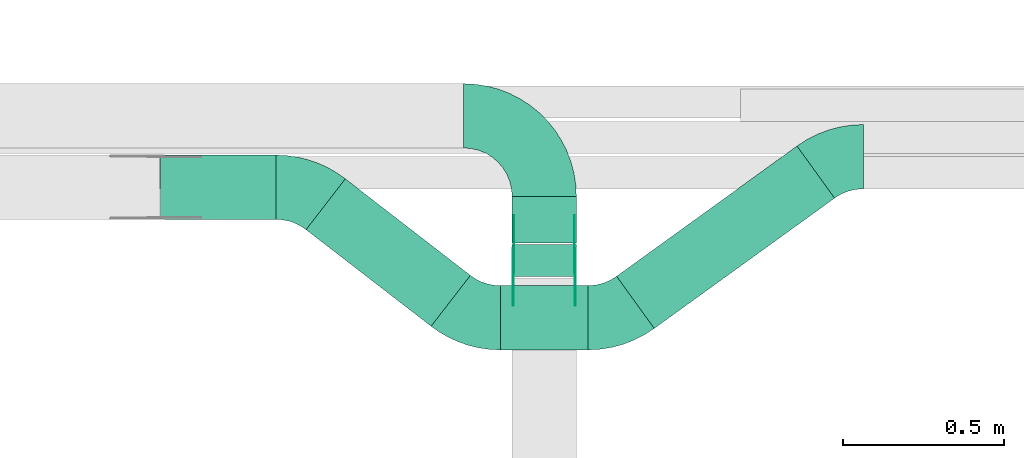
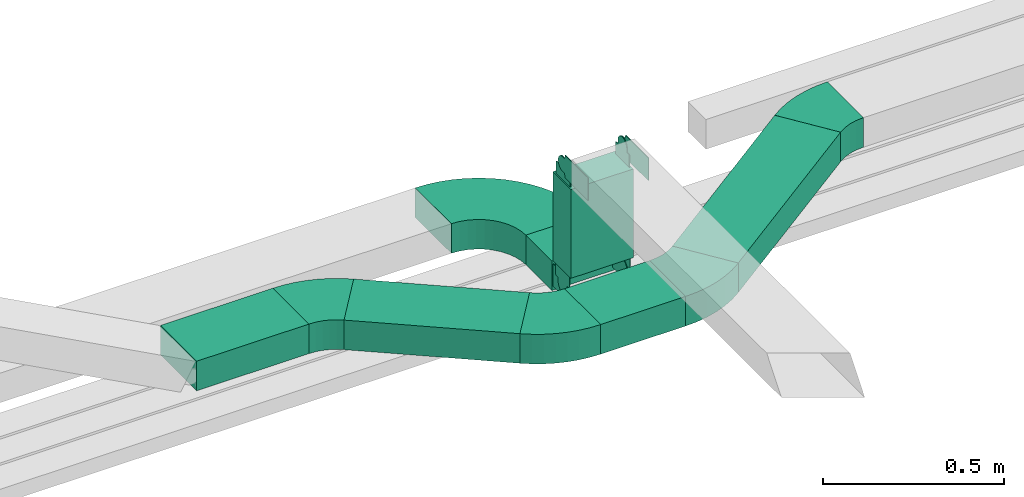
# One storey, part 5 of 23: 13 flow fittings, 6 flow segments.
"""IFC2X3 building model written with IfcOpenShell, lengths in millimetres."""

from ifc_helpers import new_model, entity, si_unit, converted_unit, derived_unit, direction, frame, frame_2d, origin, origin_2d_with_axis, place, context, subcontext, project, spatial, polyline, circle_curve, parameter, trimmed, segment, composite_curve, rectangle, outline, extrude, source, transform, mapped, material, type_object, type_shapes, element, save


model = new_model("IFC2X3")

# Units and contexts
model_context = context("Model", 3, precision=0.01, world=origin(), true_north=direction((6.12303176911189e-17, 1.0)))
body_context = subcontext(model_context, "Body", "Model", "MODEL_VIEW")
ifc_project = project(units=[si_unit("LENGTHUNIT", "METRE", prefix="MILLI"), si_unit("AREAUNIT", "SQUARE_METRE"), si_unit("VOLUMEUNIT", "CUBIC_METRE"), converted_unit("PLANEANGLEUNIT", "DEGREE", entity("IfcRatioMeasure", 0.0174532925199433), si_unit("PLANEANGLEUNIT", "RADIAN"), dimensions=[0, 0, 0, 0, 0, 0, 0]), si_unit("MASSUNIT", "GRAM", prefix="KILO"), derived_unit("MASSDENSITYUNIT", [(si_unit("MASSUNIT", "GRAM", prefix="KILO"), 1), (si_unit("LENGTHUNIT", "METRE"), -3)]), derived_unit("MOMENTOFINERTIAUNIT", [(si_unit("LENGTHUNIT", "METRE"), 4)]), si_unit("TIMEUNIT", "SECOND"), si_unit("FREQUENCYUNIT", "HERTZ"), si_unit("THERMODYNAMICTEMPERATUREUNIT", "DEGREE_CELSIUS"), derived_unit("THERMALTRANSMITTANCEUNIT", [(si_unit("MASSUNIT", "GRAM", prefix="KILO"), 1), (si_unit("THERMODYNAMICTEMPERATUREUNIT", "KELVIN"), -1), (si_unit("TIMEUNIT", "SECOND"), -3)]), derived_unit("VOLUMETRICFLOWRATEUNIT", [(si_unit("LENGTHUNIT", "METRE"), 3), (si_unit("TIMEUNIT", "SECOND"), -1)]), derived_unit("MASSFLOWRATEUNIT", [(si_unit("MASSUNIT", "GRAM", prefix="KILO"), 1), (si_unit("TIMEUNIT", "SECOND"), -1)]), derived_unit("ROTATIONALFREQUENCYUNIT", [(si_unit("TIMEUNIT", "SECOND"), -1)]), si_unit("ELECTRICCURRENTUNIT", "AMPERE"), si_unit("ELECTRICVOLTAGEUNIT", "VOLT"), si_unit("POWERUNIT", "WATT"), si_unit("FORCEUNIT", "NEWTON", prefix="KILO"), si_unit("ILLUMINANCEUNIT", "LUX"), si_unit("LUMINOUSFLUXUNIT", "LUMEN"), si_unit("LUMINOUSINTENSITYUNIT", "CANDELA"), derived_unit("USERDEFINED", [(si_unit("MASSUNIT", "GRAM", prefix="KILO"), -1), (si_unit("LENGTHUNIT", "METRE"), -2), (si_unit("TIMEUNIT", "SECOND"), 3), (si_unit("LUMINOUSFLUXUNIT", "LUMEN"), 1)]), derived_unit("LINEARVELOCITYUNIT", [(si_unit("LENGTHUNIT", "METRE"), 1), (si_unit("TIMEUNIT", "SECOND"), -1)]), si_unit("PRESSUREUNIT", "PASCAL"), derived_unit("USERDEFINED", [(si_unit("LENGTHUNIT", "METRE"), -2), (si_unit("MASSUNIT", "GRAM", prefix="KILO"), 1), (si_unit("TIMEUNIT", "SECOND"), -2)]), derived_unit("LINEARFORCEUNIT", [(si_unit("MASSUNIT", "GRAM", prefix="KILO"), 1), (si_unit("LENGTHUNIT", "METRE"), 1), (si_unit("TIMEUNIT", "SECOND"), -2), (si_unit("LENGTHUNIT", "METRE"), -1)]), derived_unit("PLANARFORCEUNIT", [(si_unit("MASSUNIT", "GRAM", prefix="KILO"), 1), (si_unit("LENGTHUNIT", "METRE"), 1), (si_unit("TIMEUNIT", "SECOND"), -2), (si_unit("LENGTHUNIT", "METRE"), -2)])], contexts=[model_context])

# Site, building, storey
site_placement = place(None, origin())
site = spatial("IfcSite", under=ifc_project, at=site_placement, CompositionType="ELEMENT")
building_placement = place(site_placement, origin())
building = spatial("IfcBuilding", under=site, at=building_placement, CompositionType="ELEMENT")
storey_placement = place(building_placement, frame((0.0, 0.0, 24000.0)))
storey = spatial("IfcBuildingStorey", under=building, at=storey_placement, CompositionType="ELEMENT", Elevation=24000.0)

# Flow segments
cable_carrier_segment_type = type_object("IfcCableCarrierSegmentType", PredefinedType="CABLETRAYSEGMENT")
flow_segment_1_placement = place(storey_placement, frame((22684.98, 9729.94, 2890.0)))
element("IfcFlowSegment", 1, at=flow_segment_1_placement, inside=storey, type_object=cable_carrier_segment_type, context=body_context, shape_type="SweptSolid", body=[
    extrude(rectangle(XDim=143.999999999998, YDim=199.999999999998, at=origin_2d_with_axis()), frame((100.0, 72.0, 0.0), z_axis=(0.0, 0.0, 1.0), x_axis=(0.0, -1.0, 0.0)), (0.0, 0.0, 1.0), 100.000000000003),
])
flow_segment_2_placement = place(storey_placement, frame((22684.98, 9624.94, 2995.0)))
element("IfcFlowSegment", 2, at=flow_segment_2_placement, inside=storey, type_object=cable_carrier_segment_type, context=body_context, shape_type="SweptSolid", body=[
    extrude(rectangle(XDim=199.999999999998, YDim=100.000000000001, at=origin_2d_with_axis()), frame((100.0, 50.0, 0.0)), (0.0, 0.0, 1.0), 299.999986293866),
])
flow_segment_3_placement = place(storey_placement, frame((21591.43, 9802.66, 2890.0)))
element("IfcFlowSegment", 3, at=flow_segment_3_placement, inside=storey, type_object=cable_carrier_segment_type, context=body_context, shape_type="SweptSolid", body=[
    extrude(rectangle(XDim=359.111266245777, YDim=199.999999999998, at=origin_2d_with_axis()), frame((179.56, 100.0, 0.0), z_axis=(0.0, 0.0, 1.0), x_axis=(-1.0, 0.0, 0.0)), (0.0, 0.0, 1.0), 100.000000000003),
])
flow_segment_4_placement = place(storey_placement, frame((22648.76, 9396.69, 2890.0)))
element("IfcFlowSegment", 4, at=flow_segment_4_placement, inside=storey, type_object=cable_carrier_segment_type, context=body_context, shape_type="SweptSolid", body=[
    extrude(rectangle(XDim=271.84445040066, YDim=200.0, at=origin_2d_with_axis()), frame((135.92, 100.0, 0.0)), (0.0, 0.0, 1.0), 100.000000000003),
])
flow_segment_5_placement = place(storey_placement, frame((22044.03, 9470.31, 2890.0)))
element("IfcFlowSegment", 5, at=flow_segment_5_placement, inside=storey, type_object=cable_carrier_segment_type, context=body_context, shape_type="SweptSolid", body=[
    extrude(rectangle(XDim=491.512542620555, YDim=200.000000000002, at=origin_2d_with_axis()), frame((255.62, 229.37, 0.0), z_axis=(0.0, 0.0, 1.0), x_axis=(-0.791406463891307, 0.611290282035514, 0.0)), (0.0, 0.0, 1.0), 100.000000000003),
])
flow_segment_6_placement = place(storey_placement, frame((23010.24, 9463.55, 2890.0)))
element("IfcFlowSegment", 6, at=flow_segment_6_placement, inside=storey, type_object=cable_carrier_segment_type, context=body_context, shape_type="SweptSolid", body=[
    extrude(rectangle(XDim=692.157993245641, YDim=200.0, at=origin_2d_with_axis()), frame((339.1, 283.71, 0.0), z_axis=(0.0, 0.0, 1.0), x_axis=(0.810643960277806, 0.585539383530361, 0.0)), (0.0, 0.0, 1.0), 100.000000000003),
])

# Flow fittings
ifc_material_1 = material()
cable_carrier_fitting_type_1 = type_object("IfcCableCarrierFittingType", Name="470_DKC_S5_Variable Angle Elbow 0-45:-", PredefinedType="NOTDEFINED", material=ifc_material_1)
shared_shape_1 = source(origin(), body_context, "Body", "SweptSolid", [
    extrude(outline(composite_curve([segment(polyline([(-125.75, -225.25), (-124.75, -225.25)]), True, "CONTINUOUS"), segment(trimmed(circle_curve(frame_2d((-124.75, 124.75), x_axis=(0.0, -1.0)), 350.0), [parameter(0.0)], [parameter(90.0000000000001)], True, "PARAMETER"), True, "CONTINUOUS"), segment(polyline([(225.25, 124.75), (225.25, 125.75)]), True, "CONTINUOUS"), segment(polyline([(225.25, 125.75), (25.25, 125.75)]), True, "CONTINUOUS"), segment(polyline([(25.25, 125.75), (25.25, 124.75)]), True, "CONTINUOUS"), segment(trimmed(circle_curve(frame_2d((-124.75, 124.75), x_axis=(0.0, -1.0)), 150.0), [parameter(0.0)], [parameter(90.0000000000001)], True, "PARAMETER"), False, "CONTINUOUS"), segment(polyline([(-124.75, -25.25), (-125.75, -25.25)]), True, "CONTINUOUS"), segment(polyline([(-125.75, -25.25), (-125.75, -225.25)]), True, "CONTINUOUS")], self_intersect=False)), frame((-125.25, 125.25, -50.0)), (0.0, 0.0, 1.0), 100.0),
])
type_shapes(cable_carrier_fitting_type_1, [shared_shape_1])
flow_fitting_1_placement = place(storey_placement, frame((22784.98, 10124.94, 2940.0), z_axis=(0.0, 0.0, 1.0), x_axis=(0.0, 1.0, 0.0)))
element("IfcFlowFitting", 7, at=flow_fitting_1_placement, inside=storey, type_object=cable_carrier_fitting_type_1, material=ifc_material_1, Name="470_DKC_S5_Variable Angle Elbow 0-45:-", ObjectType="470_DKC_S5_Variable Angle Elbow 0-45:-", context=body_context, shape_type="MappedRepresentation", body=[
    mapped(shared_shape_1, transform((0.0, 0.0, 0.0), scale=1.0)),
])
ifc_material_2 = material(Name="G")
cable_carrier_fitting_type_2 = type_object("IfcCableCarrierFittingType", PredefinedType="NOTDEFINED", material=ifc_material_2)
shared_shape_2 = source(origin(), body_context, "Body", "SweptSolid", [
    extrude(outline(composite_curve([segment(trimmed(circle_curve(frame_2d((-41.47, 0.0), x_axis=(1.0, 0.0)), 25.0), [parameter(90.0000000000007)], [parameter(270.0)], True, "PARAMETER"), True, "CONTINUOUS"), segment(polyline([(-41.47, -25.0), (-29.97, -25.0)]), True, "CONTINUOUS"), segment(polyline([(-29.97, -25.0), (-28.1, -38.5)]), True, "CONTINUOUS"), segment(polyline([(-28.1, -38.5), (99.53, -38.5)]), True, "CONTINUOUS"), segment(polyline([(99.53, -38.5), (99.53, 38.5)]), True, "CONTINUOUS"), segment(polyline([(99.53, 38.5), (-28.1, 38.5)]), True, "CONTINUOUS"), segment(polyline([(-28.1, 38.5), (-29.97, 25.0)]), True, "CONTINUOUS"), segment(polyline([(-29.97, 25.0), (-41.47, 25.0)]), True, "CONTINUOUS")], self_intersect=False)), frame((41.47, 0.0, 0.0), z_axis=(0.0, 0.0, -1.0), x_axis=(1.0, 0.0, 0.0)), (0.0, 0.0, -1.0), 2.0),
])
type_shapes(cable_carrier_fitting_type_2, [shared_shape_2])
flow_fitting_2_placement = place(storey_placement, frame((22880.44, 9674.94, 3350.0), z_axis=(1.0, 0.0, 0.0), x_axis=(0.0, -1.0, -2.53817257434008e-07)))
element("IfcFlowFitting", 8, at=flow_fitting_2_placement, inside=storey, type_object=cable_carrier_fitting_type_2, material=ifc_material_2, context=body_context, shape_type="MappedRepresentation", body=[
    mapped(shared_shape_2, transform((0.0, 0.0, 0.0), scale=1.0)),
])
cable_carrier_fitting_type_3 = type_object("IfcCableCarrierFittingType", PredefinedType="NOTDEFINED", material=ifc_material_2)
type_shapes(cable_carrier_fitting_type_3, [shared_shape_2])
flow_fitting_3_placement = place(storey_placement, frame((22691.52, 9674.94, 3350.0), z_axis=(-1.0, 0.0, 0.0), x_axis=(0.0, 0.0, -1.0)))
element("IfcFlowFitting", 9, at=flow_fitting_3_placement, inside=storey, type_object=cable_carrier_fitting_type_3, material=ifc_material_2, context=body_context, shape_type="MappedRepresentation", body=[
    mapped(shared_shape_2, transform((0.0, 0.0, 0.0), scale=1.0)),
])
flow_fitting_4_placement = place(storey_placement, frame((22689.52, 9674.94, 2940.0), z_axis=(-1.0, 0.0, 0.0), x_axis=(0.0, 0.0, 1.0)))
element("IfcFlowFitting", 10, at=flow_fitting_4_placement, inside=storey, type_object=cable_carrier_fitting_type_2, material=ifc_material_2, context=body_context, shape_type="MappedRepresentation", body=[
    mapped(shared_shape_2, transform((0.0, 0.0, 0.0), scale=1.0)),
])
flow_fitting_5_placement = place(storey_placement, frame((22878.44, 9674.94, 2940.0), z_axis=(1.0, 0.0, 0.0), x_axis=(0.0, 1.0, 0.0)))
element("IfcFlowFitting", 11, at=flow_fitting_5_placement, inside=storey, type_object=cable_carrier_fitting_type_3, material=ifc_material_2, context=body_context, shape_type="MappedRepresentation", body=[
    mapped(shared_shape_2, transform((0.0, 0.0, 0.0), scale=1.0)),
])
cable_carrier_fitting_type_4 = type_object("IfcCableCarrierFittingType", PredefinedType="NOTDEFINED", material=ifc_material_2)
shared_shape_3 = source(origin(), body_context, "Body", "SweptSolid", [
    extrude(outline(composite_curve([segment(trimmed(circle_curve(frame_2d((-41.47, 0.0), x_axis=(1.0, 0.0)), 25.0), [parameter(90.0000000000007)], [parameter(270.0)], True, "PARAMETER"), True, "CONTINUOUS"), segment(polyline([(-41.47, -25.0), (-29.97, -25.0)]), True, "CONTINUOUS"), segment(polyline([(-29.97, -25.0), (-28.1, -38.5)]), True, "CONTINUOUS"), segment(polyline([(-28.1, -38.5), (99.53, -38.5)]), True, "CONTINUOUS"), segment(polyline([(99.53, -38.5), (99.53, 38.5)]), True, "CONTINUOUS"), segment(polyline([(99.53, 38.5), (-28.1, 38.5)]), True, "CONTINUOUS"), segment(polyline([(-28.1, 38.5), (-29.97, 25.0)]), True, "CONTINUOUS"), segment(polyline([(-29.97, 25.0), (-41.47, 25.0)]), True, "CONTINUOUS")], self_intersect=False)), frame((41.47, 0.0, 0.0)), (0.0, 0.0, 1.0), 2.0),
])
type_shapes(cable_carrier_fitting_type_4, [shared_shape_3])
flow_fitting_6_placement = place(storey_placement, frame((22689.52, 9674.94, 3350.0), z_axis=(-1.0, 0.0, 0.0), x_axis=(0.0, -1.0, -2.53817257434008e-07)))
element("IfcFlowFitting", 12, at=flow_fitting_6_placement, inside=storey, type_object=cable_carrier_fitting_type_4, material=ifc_material_2, context=body_context, shape_type="MappedRepresentation", body=[
    mapped(shared_shape_3, transform((0.0, 0.0, 0.0), scale=1.0)),
])
cable_carrier_fitting_type_5 = type_object("IfcCableCarrierFittingType", PredefinedType="NOTDEFINED", material=ifc_material_2)
type_shapes(cable_carrier_fitting_type_5, [shared_shape_3])
flow_fitting_7_placement = place(storey_placement, frame((22878.44, 9674.94, 3350.0), z_axis=(1.0, 0.0, 0.0), x_axis=(0.0, 0.0, -1.0)))
element("IfcFlowFitting", 13, at=flow_fitting_7_placement, inside=storey, type_object=cable_carrier_fitting_type_5, material=ifc_material_2, context=body_context, shape_type="MappedRepresentation", body=[
    mapped(shared_shape_3, transform((0.0, 0.0, 0.0), scale=1.0)),
])
flow_fitting_8_placement = place(storey_placement, frame((22880.44, 9674.94, 2940.0), z_axis=(1.0, 0.0, 0.0), x_axis=(0.0, 0.0, 1.0)))
element("IfcFlowFitting", 14, at=flow_fitting_8_placement, inside=storey, type_object=cable_carrier_fitting_type_4, material=ifc_material_2, context=body_context, shape_type="MappedRepresentation", body=[
    mapped(shared_shape_3, transform((0.0, 0.0, 0.0), scale=1.0)),
])
flow_fitting_9_placement = place(storey_placement, frame((22691.52, 9674.94, 2940.0), z_axis=(-1.0, 0.0, 0.0), x_axis=(0.0, 1.0, 0.0)))
element("IfcFlowFitting", 15, at=flow_fitting_9_placement, inside=storey, type_object=cable_carrier_fitting_type_5, material=ifc_material_2, context=body_context, shape_type="MappedRepresentation", body=[
    mapped(shared_shape_3, transform((0.0, 0.0, 0.0), scale=1.0)),
])
cable_carrier_fitting_type_6 = type_object("IfcCableCarrierFittingType", Name="470_DKC_S5_Variable Angle Elbow 0-45:-", PredefinedType="NOTDEFINED", material=ifc_material_1)
shared_shape_4 = source(origin(), body_context, "Body", "SweptSolid", [
    extrude(outline(composite_curve([segment(polyline([(-77.36, -126.23), (-76.36, -126.23)]), True, "CONTINUOUS"), segment(trimmed(circle_curve(frame_2d((-76.36, 223.77), x_axis=(0.0, -1.0)), 350.0), [parameter(0.0)], [parameter(37.6828573416333)], True, "PARAMETER"), True, "CONTINUOUS"), segment(polyline([(137.59, -53.22), (138.38, -52.61)]), True, "CONTINUOUS"), segment(polyline([(138.38, -52.61), (16.13, 105.67)]), True, "CONTINUOUS"), segment(polyline([(16.13, 105.67), (15.33, 105.06)]), True, "CONTINUOUS"), segment(trimmed(circle_curve(frame_2d((-76.36, 223.77), x_axis=(0.0, -1.0)), 150.0), [parameter(0.0)], [parameter(37.6828573416333)], True, "PARAMETER"), False, "CONTINUOUS"), segment(polyline([(-76.36, 73.77), (-77.36, 73.77)]), True, "CONTINUOUS"), segment(polyline([(-77.36, 73.77), (-77.36, -126.23)]), True, "CONTINUOUS")], self_intersect=False)), frame((-8.95, 26.23, -50.0)), (0.0, 0.0, 1.0), 100.0),
])
type_shapes(cable_carrier_fitting_type_6, [shared_shape_4])
for number, where, z_axis, x_axis, name in (
    (16, (22562.45, 9496.69, 2940.0), (0.0, 0.0, 1.0), (0.791406463891316, -0.611290282035502, 0.0), "470_DKC_S5_Variable Angle Elbow 0-45:-"),
    (17, (22036.85, 9902.66, 2940.0), (0.0, 0.0, 1.0), (-0.791406463891307, 0.611290282035514, 0.0), "470_DKC_S5_Variable Angle Elbow 0-45:-"),
):
    element("IfcFlowFitting", number, at=place(storey_placement, frame(where, z_axis=z_axis, x_axis=x_axis)), inside=storey, type_object=cable_carrier_fitting_type_6, material=ifc_material_1, Name=name, ObjectType="470_DKC_S5_Variable Angle Elbow 0-45:-", context=body_context, shape_type="MappedRepresentation", body=[
        mapped(shared_shape_4, transform((0.0, 0.0, 0.0), scale=1.0)),
    ])
cable_carrier_fitting_type_7 = type_object("IfcCableCarrierFittingType", Name="470_DKC_S5_Variable Angle Elbow 0-45:-", PredefinedType="NOTDEFINED", material=ifc_material_1)
shared_shape_5 = source(origin(), body_context, "Body", "SweptSolid", [
    extrude(outline(composite_curve([segment(polyline([(-74.15, -123.82), (-73.15, -123.82)]), True, "CONTINUOUS"), segment(trimmed(circle_curve(frame_2d((-73.15, 226.18), x_axis=(0.0, -1.0)), 350.0), [parameter(0.0)], [parameter(35.8411041291456)], True, "PARAMETER"), True, "CONTINUOUS"), segment(polyline([(131.79, -57.54), (132.6, -56.96)]), True, "CONTINUOUS"), segment(polyline([(132.6, -56.96), (15.5, 105.17)]), True, "CONTINUOUS"), segment(polyline([(15.5, 105.17), (14.69, 104.59)]), True, "CONTINUOUS"), segment(trimmed(circle_curve(frame_2d((-73.15, 226.18), x_axis=(0.0, -1.0)), 150.0), [parameter(0.0)], [parameter(35.8411041291456)], True, "PARAMETER"), False, "CONTINUOUS"), segment(polyline([(-73.15, 76.18), (-74.15, 76.18)]), True, "CONTINUOUS"), segment(polyline([(-74.15, 76.18), (-74.15, -123.82)]), True, "CONTINUOUS")], self_intersect=False)), frame((-7.7, 23.82, -50.0)), (0.0, 0.0, 1.0), 100.0),
])
type_shapes(cable_carrier_fitting_type_7, [shared_shape_5])
flow_fitting_10_placement = place(storey_placement, frame((23002.45, 9496.69, 2940.0)))
element("IfcFlowFitting", 18, at=flow_fitting_10_placement, inside=storey, type_object=cable_carrier_fitting_type_7, material=ifc_material_1, Name="470_DKC_S5_Variable Angle Elbow 0-45:-", ObjectType="470_DKC_S5_Variable Angle Elbow 0-45:-", context=body_context, shape_type="MappedRepresentation", body=[
    mapped(shared_shape_5, transform((0.0, 0.0, 0.0), scale=1.0)),
])
flow_fitting_11_placement = place(storey_placement, frame((23696.24, 9997.82, 2940.0), z_axis=(0.0, 0.0, 1.0), x_axis=(-1.0, 0.0, 0.0)))
element("IfcFlowFitting", 19, at=flow_fitting_11_placement, inside=storey, type_object=cable_carrier_fitting_type_7, material=ifc_material_1, Name="470_DKC_S5_Variable Angle Elbow 0-45:-", ObjectType="470_DKC_S5_Variable Angle Elbow 0-45:-", context=body_context, shape_type="MappedRepresentation", body=[
    mapped(shared_shape_5, transform((0.0, 0.0, 0.0), scale=1.0)),
])

save(model, "model.ifc")
